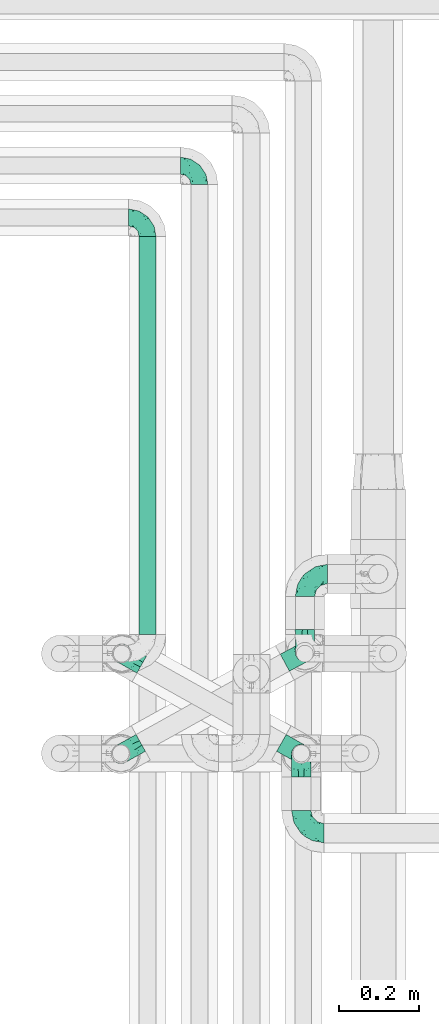
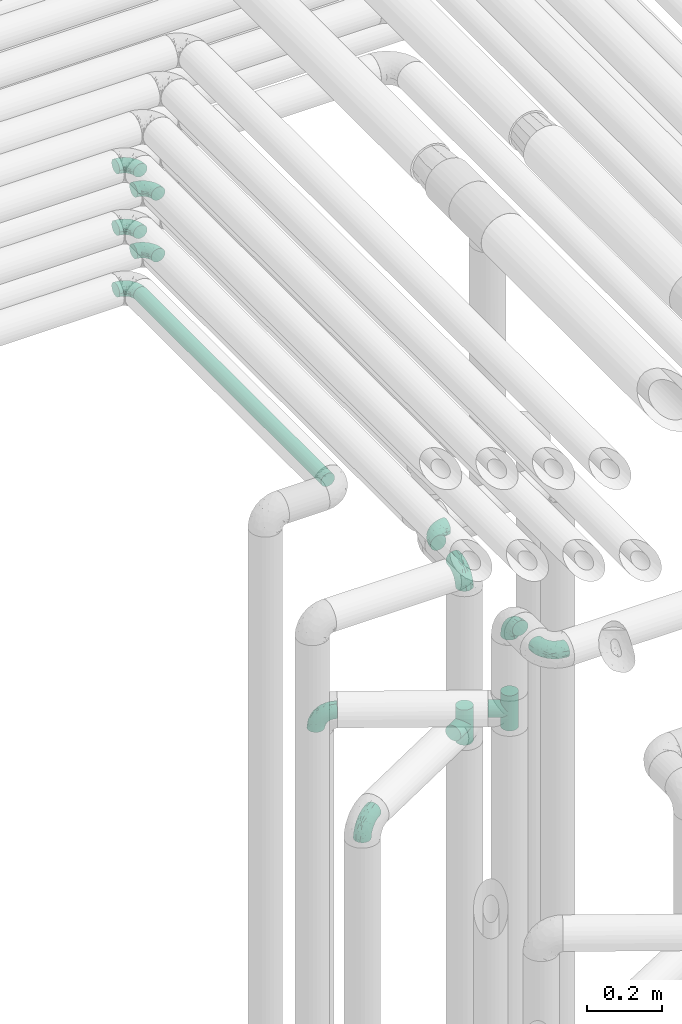
# One storey, part 601 of 824: 13 flow fittings, 1 flow segment.
"""IFC2X3 building model written with IfcOpenShell, lengths in millimetres."""

from ifc_helpers import new_model, entity, si_unit, converted_unit, derived_unit, direction, frame, origin, origin_2d_with_axis, place, context, subcontext, project, spatial, circle, extrude, faceted_brep, source, transform, mapped, material, type_object, type_shapes, element, save


model = new_model("IFC2X3")

# Units and contexts
model_context = context("Model", 3, precision=0.01, world=origin(), true_north=direction((6.12303176911189e-17, 1.0)))
body_context = subcontext(model_context, "Body", "Model", "MODEL_VIEW")
ifc_project = project(units=[si_unit("LENGTHUNIT", "METRE", prefix="MILLI"), si_unit("AREAUNIT", "SQUARE_METRE"), si_unit("VOLUMEUNIT", "CUBIC_METRE"), converted_unit("PLANEANGLEUNIT", "DEGREE", entity("IfcRatioMeasure", 0.0174532925199433), si_unit("PLANEANGLEUNIT", "RADIAN"), dimensions=[0, 0, 0, 0, 0, 0, 0]), si_unit("MASSUNIT", "GRAM", prefix="KILO"), derived_unit("MASSDENSITYUNIT", [(si_unit("MASSUNIT", "GRAM", prefix="KILO"), 1), (si_unit("LENGTHUNIT", "METRE"), -3)]), derived_unit("MOMENTOFINERTIAUNIT", [(si_unit("LENGTHUNIT", "METRE"), 4)]), si_unit("TIMEUNIT", "SECOND"), si_unit("FREQUENCYUNIT", "HERTZ"), si_unit("THERMODYNAMICTEMPERATUREUNIT", "DEGREE_CELSIUS"), derived_unit("THERMALTRANSMITTANCEUNIT", [(si_unit("MASSUNIT", "GRAM", prefix="KILO"), 1), (si_unit("THERMODYNAMICTEMPERATUREUNIT", "KELVIN"), -1), (si_unit("TIMEUNIT", "SECOND"), -3)]), derived_unit("VOLUMETRICFLOWRATEUNIT", [(si_unit("LENGTHUNIT", "METRE"), 3), (si_unit("TIMEUNIT", "SECOND"), -1)]), derived_unit("MASSFLOWRATEUNIT", [(si_unit("MASSUNIT", "GRAM", prefix="KILO"), 1), (si_unit("TIMEUNIT", "SECOND"), -1)]), derived_unit("ROTATIONALFREQUENCYUNIT", [(si_unit("TIMEUNIT", "SECOND"), -1)]), si_unit("ELECTRICCURRENTUNIT", "AMPERE"), si_unit("ELECTRICVOLTAGEUNIT", "VOLT"), si_unit("POWERUNIT", "WATT"), si_unit("FORCEUNIT", "NEWTON", prefix="KILO"), si_unit("ILLUMINANCEUNIT", "LUX"), si_unit("LUMINOUSFLUXUNIT", "LUMEN"), si_unit("LUMINOUSINTENSITYUNIT", "CANDELA"), derived_unit("USERDEFINED", [(si_unit("MASSUNIT", "GRAM", prefix="KILO"), -1), (si_unit("LENGTHUNIT", "METRE"), -2), (si_unit("TIMEUNIT", "SECOND"), 3), (si_unit("LUMINOUSFLUXUNIT", "LUMEN"), 1)]), derived_unit("LINEARVELOCITYUNIT", [(si_unit("LENGTHUNIT", "METRE"), 1), (si_unit("TIMEUNIT", "SECOND"), -1)]), si_unit("PRESSUREUNIT", "PASCAL"), derived_unit("USERDEFINED", [(si_unit("LENGTHUNIT", "METRE"), -2), (si_unit("MASSUNIT", "GRAM", prefix="KILO"), 1), (si_unit("TIMEUNIT", "SECOND"), -2)]), derived_unit("LINEARFORCEUNIT", [(si_unit("MASSUNIT", "GRAM", prefix="KILO"), 1), (si_unit("LENGTHUNIT", "METRE"), 1), (si_unit("TIMEUNIT", "SECOND"), -2), (si_unit("LENGTHUNIT", "METRE"), -1)]), derived_unit("PLANARFORCEUNIT", [(si_unit("MASSUNIT", "GRAM", prefix="KILO"), 1), (si_unit("LENGTHUNIT", "METRE"), 1), (si_unit("TIMEUNIT", "SECOND"), -2), (si_unit("LENGTHUNIT", "METRE"), -2)])], contexts=[model_context])

# Site, building, storey
site_placement = place(None, origin())
site = spatial("IfcSite", under=ifc_project, at=site_placement, CompositionType="ELEMENT")
building_placement = place(site_placement, origin())
building = spatial("IfcBuilding", under=site, at=building_placement, CompositionType="ELEMENT")
storey_placement = place(building_placement, frame((0.0, 0.0, 28200.0)))
storey = spatial("IfcBuildingStorey", under=building, at=storey_placement, CompositionType="ELEMENT", Elevation=28200.0)

# Flow segment
pipe_segment_type = type_object("IfcPipeSegmentType", PredefinedType="NOTDEFINED")
flow_segment_placement = place(storey_placement, frame((35317.29, 13054.2, 2977.25)))
element("IfcFlowSegment", 1, at=flow_segment_placement, inside=storey, type_object=pipe_segment_type, context=body_context, shape_type="SweptSolid", body=[
    extrude(circle(Radius=21.15, at=origin_2d_with_axis()), frame((22.75, 0.0, 22.75), z_axis=(0.0, 1.0, 0.0), x_axis=(-1.0, 0.0, 0.0)), (0.0, 0.0, 1.0), 997.797074054168),
])

# Flow fittings
ifc_material = material()
pipe_fitting_type_1 = type_object("IfcPipeFittingType", PredefinedType="NOTDEFINED", material=ifc_material)
shared_shape_1 = source(origin(), body_context, "Body", "Brep", [
    faceted_brep([(-57.0, 12.07, -20.91), (-57.0, 6.25, -23.33), (-57.0, 0.0, -24.15), (-57.0, -6.25, -23.33), (-57.0, -12.08, -20.91), (-57.0, -17.08, -17.08), (-57.0, -20.91, -12.08), (-57.0, -23.33, -6.25), (-57.0, -24.15, 0.0), (-57.0, -23.33, 6.25), (-57.0, -20.91, 12.07), (-57.0, -17.08, 17.08), (-57.0, -12.08, 20.91), (-57.0, -6.25, 23.33), (-57.0, 0.0, 24.15), (-57.0, 6.25, 23.33), (-57.0, 12.07, 20.91), (-57.0, 17.08, 17.08), (-57.0, 20.91, 12.07), (-57.0, 23.33, 6.25), (-57.0, 24.15, 0.0), (-57.0, 23.33, -6.25), (-57.0, 20.91, -12.08), (-57.0, 17.08, -17.08), (0.0, 57.0, -24.15), (-6.25, 57.0, -23.33), (-12.07, 57.0, -20.91), (-17.08, 57.0, -17.08), (-20.91, 57.0, -12.08), (-23.33, 57.0, -6.25), (-24.15, 57.0, 0.0), (-23.33, 57.0, 6.25), (-20.91, 57.0, 12.07), (-17.08, 57.0, 17.08), (-12.07, 57.0, 20.91), (-6.25, 57.0, 23.33), (0.0, 57.0, 24.15), (6.25, 57.0, 23.33), (12.08, 57.0, 20.91), (17.08, 57.0, 17.08), (20.91, 57.0, 12.07), (23.33, 57.0, 6.25), (24.15, 57.0, 0.0), (23.33, 57.0, -6.25), (20.91, 57.0, -12.08), (17.08, 57.0, -17.08), (12.08, 57.0, -20.91), (6.25, 57.0, -23.33), (14.9, 21.14, 6.17), (13.61, 24.64, 12.48), (6.23, 8.95, 8.98), (-41.47, -21.06, 0.0), (-41.92, -18.38, 13.72), (-24.64, -13.61, 12.48), (-37.37, -13.24, 18.15), (-6.8, -4.93, 8.18), (-21.76, -15.19, 6.22), (-12.78, -9.18, 0.0), (-37.73, -20.51, 7.75), (-7.38, 7.38, 20.24), (-23.37, -4.26, 20.42), (-11.9, -3.19, 15.86), (-42.14, -8.7, 21.82), (13.24, 37.37, 18.15), (9.33, 23.53, 16.85), (4.26, 23.37, 20.42), (2.77, 10.92, 15.55), (-29.46, 0.91, 23.52), (-44.13, 20.56, 15.69), (-39.25, 26.33, 10.88), (-49.02, 22.92, 9.96), (-34.58, 23.87, 17.15), (-15.8, 6.8, 22.81), (-8.67, 20.47, 23.88), (-18.12, 12.9, 24.08), (-48.29, 14.92, 19.65), (-44.06, -2.85, 23.78), (-9.23, 48.95, 22.58), (-3.78, 42.74, 24.07), (-40.34, 4.26, 24.09), (-44.02, 26.14, 5.46), (-44.04, 9.88, 22.74), (-4.95, 16.87, 22.52), (-2.75, 1.43, 12.5), (-25.48, 40.98, 10.71), (20.51, 37.73, 7.75), (18.38, 41.92, 13.72), (8.7, 42.14, 21.82), (-25.95, -17.97, 0.0), (2.85, 44.06, 23.78), (21.06, 41.47, 0.0), (17.97, 25.95, 0.0), (-24.04, -9.27, 17.13), (-33.26, 33.26, 5.86), (-28.55, 40.57, 0.0), (-40.57, 28.55, 0.0), (-25.29, 47.19, 4.06), (-27.01, 31.1, 16.77), (-15.7, 43.95, 19.9), (-20.27, 45.22, 15.61), (-30.53, 31.98, 12.64), (-11.28, 38.33, 22.92), (-9.97, 27.88, 24.09), (-20.15, 30.26, 21.25), (-31.25, 11.75, 23.64), (-28.75, 7.23, 24.15), (-29.53, 18.06, 22.27), (-28.44, 24.21, 20.02), (-37.55, 17.7, 20.26), (-15.88, 29.25, 22.99), (-20.82, 20.82, 23.44), (-0.91, 29.46, 23.52), (-13.5, -7.67, 12.04), (1.49, 1.56, 5.16), (8.86, 10.35, 4.59), (0.38, -0.38, 0.0), (9.18, 12.78, 0.0), (-37.37, -13.24, -18.15), (8.86, 10.35, -4.59), (-45.22, 20.27, -15.61), (-43.95, 15.7, -19.9), (-38.33, 11.28, -22.92), (-48.95, 9.23, -22.58), (-47.19, 25.29, -4.06), (-33.26, 33.26, -5.86), (18.38, 41.92, -13.72), (-30.26, 20.15, -21.25), (2.85, 44.06, -23.78), (-4.26, 40.34, -24.09), (-40.98, 25.48, -10.71), (-41.92, -18.38, -13.72), (9.25, 23.5, -16.92), (4.26, 23.37, -20.42), (13.24, 37.37, -18.15), (-37.73, -20.51, -7.75), (-11.75, 31.25, -23.64), (-7.23, 28.75, -24.15), (-12.9, 18.12, -24.08), (8.7, 42.14, -21.82), (-44.06, -2.85, -23.78), (-6.8, 15.8, -22.81), (-20.47, 8.67, -23.88), (-24.64, -13.61, -12.48), (-42.74, 3.78, -24.07), (-18.06, 29.53, -22.27), (-24.21, 28.44, -20.02), (-27.88, 9.97, -24.09), (-31.1, 27.01, -16.77), (-26.14, 44.02, -5.46), (14.9, 21.14, -6.17), (20.51, 37.73, -7.75), (-9.88, 44.04, -22.74), (-20.56, 44.13, -15.69), (-21.76, -15.19, -6.22), (-13.5, -7.67, -12.04), (-24.14, -9.76, -16.74), (-11.9, -3.19, -15.86), (-14.92, 48.29, -19.65), (-23.37, -4.26, -20.42), (-0.91, 29.46, -23.52), (-26.33, 39.25, -10.88), (-23.87, 34.58, -17.15), (-42.14, -8.7, -21.82), (-22.92, 49.02, -9.96), (13.61, 24.64, -12.48), (-31.98, 30.53, -12.64), (-16.87, 4.95, -22.52), (-17.7, 37.55, -20.26), (-29.25, 15.88, -22.99), (-20.82, 20.82, -23.44), (-29.46, 0.91, -23.52), (-7.38, 7.38, -20.24), (2.77, 10.92, -15.55), (6.23, 8.95, -8.98), (-6.8, -4.93, -8.18), (-2.81, 1.41, -12.54), (1.49, 1.56, -5.16)], [[[0, 1, 2, 3, 4, 5, 6, 7, 8, 9, 10, 11, 12, 13, 14, 15, 16, 17, 18, 19, 20, 21, 22, 23]], [[24, 25, 26, 27, 28, 29, 30, 31, 32, 33, 34, 35, 36, 37, 38, 39, 40, 41, 42, 43, 44, 45, 46, 47]], [[48, 49, 50]], [[9, 8, 51]], [[52, 53, 54]], [[55, 56, 57]], [[10, 58, 52]], [[9, 58, 10]], [[59, 60, 61]], [[54, 12, 11]], [[54, 62, 12]], [[63, 39, 38]], [[64, 65, 66]], [[62, 60, 67]], [[68, 69, 70]], [[71, 69, 68]], [[72, 73, 74]], [[16, 75, 17]], [[13, 76, 14]], [[35, 77, 78]], [[14, 79, 15]], [[17, 68, 18]], [[14, 76, 79]], [[20, 19, 80]], [[70, 19, 18]], [[81, 15, 79]], [[15, 81, 16]], [[73, 72, 82]], [[66, 83, 50]], [[32, 31, 84]], [[85, 86, 49]], [[63, 87, 65]], [[56, 58, 88]], [[36, 89, 37]], [[85, 41, 40]], [[36, 35, 78]], [[90, 41, 85]], [[40, 39, 86]], [[12, 62, 13]], [[86, 85, 40]], [[48, 85, 49]], [[85, 91, 90]], [[87, 38, 37]], [[92, 60, 54]], [[80, 69, 93]], [[93, 94, 95]], [[10, 52, 11]], [[94, 96, 30]], [[97, 98, 99]], [[80, 93, 95]], [[100, 97, 84]], [[99, 98, 33]], [[101, 102, 78]], [[103, 101, 98]], [[96, 31, 30]], [[77, 98, 101]], [[77, 35, 34]], [[34, 33, 98]], [[9, 51, 58]], [[87, 63, 38]], [[104, 105, 74]], [[106, 103, 107]], [[106, 81, 104]], [[75, 68, 17]], [[108, 107, 71]], [[33, 32, 99]], [[109, 103, 110]], [[101, 109, 102]], [[89, 78, 111]], [[53, 52, 58]], [[54, 11, 52]], [[60, 62, 54]], [[88, 58, 51]], [[76, 62, 67]], [[53, 112, 92]], [[60, 59, 72]], [[39, 63, 86]], [[49, 86, 63]], [[89, 87, 37]], [[42, 41, 90]], [[111, 82, 65]], [[111, 65, 87]], [[65, 59, 66]], [[104, 81, 79]], [[75, 81, 108]], [[32, 84, 99]], [[97, 99, 84]], [[98, 97, 103]], [[106, 107, 108]], [[74, 102, 110]], [[111, 78, 102]], [[74, 110, 104]], [[74, 67, 72]], [[61, 92, 112]], [[66, 59, 61]], [[56, 53, 58]], [[66, 50, 49]], [[61, 112, 83]], [[66, 49, 64]], [[78, 89, 36]], [[87, 89, 111]], [[62, 76, 13]], [[79, 76, 67]], [[100, 93, 69]], [[96, 93, 84]], [[55, 113, 50]], [[113, 114, 50]], [[104, 79, 105]], [[106, 104, 110]], [[20, 80, 95]], [[85, 48, 91]], [[115, 114, 113]], [[116, 91, 48]], [[70, 80, 19]], [[93, 96, 94]], [[84, 31, 96]], [[103, 106, 110]], [[81, 106, 108]], [[103, 97, 107]], [[71, 107, 97]], [[71, 97, 100]], [[108, 71, 68]], [[79, 67, 105]], [[67, 74, 105]], [[115, 113, 57]], [[112, 56, 55]], [[56, 88, 57]], [[60, 72, 67]], [[82, 72, 59]], [[65, 82, 59]], [[82, 111, 73]], [[111, 102, 73]], [[102, 74, 73]], [[81, 75, 16]], [[68, 75, 108]], [[68, 70, 18]], [[80, 70, 69]], [[98, 77, 34]], [[78, 77, 101]], [[93, 100, 84]], [[71, 100, 69]], [[102, 109, 110]], [[101, 103, 109]], [[53, 92, 54]], [[61, 60, 92]], [[56, 112, 53]], [[83, 112, 55]], [[50, 83, 55]], [[61, 83, 66]], [[49, 63, 64]], [[65, 64, 63]], [[57, 113, 55]], [[114, 115, 116]], [[116, 48, 114]], [[48, 50, 114]], [[117, 5, 4]], [[116, 115, 118]], [[119, 120, 23]], [[121, 122, 120]], [[95, 123, 20]], [[0, 23, 120]], [[124, 95, 94]], [[125, 45, 44]], [[121, 120, 126]], [[24, 127, 128]], [[22, 21, 129]], [[0, 122, 1]], [[5, 117, 130]], [[131, 132, 133]], [[134, 88, 51]], [[135, 136, 137]], [[6, 5, 130]], [[46, 138, 47]], [[139, 3, 2]], [[140, 141, 137]], [[6, 134, 7]], [[134, 130, 142]], [[143, 2, 1]], [[144, 126, 145]], [[121, 146, 143]], [[147, 120, 119]], [[94, 148, 124]], [[149, 150, 91]], [[30, 29, 148]], [[151, 25, 128]], [[27, 152, 28]], [[134, 153, 88]], [[154, 155, 156]], [[27, 26, 157]], [[151, 26, 25]], [[155, 158, 156]], [[24, 47, 127]], [[1, 122, 143]], [[138, 132, 159]], [[160, 152, 161]], [[24, 128, 25]], [[46, 133, 138]], [[162, 117, 4]], [[148, 160, 124]], [[152, 160, 163]], [[154, 142, 155]], [[45, 125, 133]], [[133, 46, 45]], [[125, 164, 133]], [[51, 7, 134]], [[42, 90, 43]], [[165, 147, 129]], [[153, 134, 142]], [[43, 150, 44]], [[162, 4, 3]], [[141, 140, 166]], [[117, 162, 158]], [[163, 29, 28]], [[43, 90, 150]], [[123, 21, 20]], [[144, 151, 135]], [[157, 152, 27]], [[167, 145, 161]], [[23, 22, 119]], [[168, 126, 169]], [[121, 168, 146]], [[139, 143, 170]], [[142, 130, 117]], [[8, 7, 51]], [[134, 6, 130]], [[139, 162, 3]], [[170, 166, 158]], [[170, 158, 162]], [[158, 171, 156]], [[44, 150, 125]], [[91, 150, 90]], [[164, 125, 150]], [[132, 138, 133]], [[127, 138, 159]], [[131, 164, 172]], [[132, 171, 140]], [[135, 151, 128]], [[157, 151, 167]], [[22, 129, 119]], [[147, 119, 129]], [[120, 147, 126]], [[144, 145, 167]], [[137, 146, 169]], [[170, 143, 146]], [[137, 169, 135]], [[137, 159, 140]], [[171, 172, 156]], [[173, 174, 175]], [[156, 175, 154]], [[174, 57, 153]], [[132, 172, 171]], [[172, 164, 173]], [[143, 139, 2]], [[162, 139, 170]], [[138, 127, 47]], [[128, 127, 159]], [[165, 124, 160]], [[123, 124, 129]], [[149, 173, 164]], [[176, 174, 173]], [[135, 128, 136]], [[144, 135, 169]], [[150, 149, 164]], [[176, 118, 115]], [[149, 91, 116]], [[30, 148, 94]], [[163, 148, 29]], [[124, 123, 95]], [[129, 21, 123]], [[126, 144, 169]], [[151, 144, 167]], [[126, 147, 145]], [[161, 145, 147]], [[161, 147, 165]], [[167, 161, 152]], [[128, 159, 136]], [[159, 137, 136]], [[154, 153, 142]], [[132, 140, 159]], [[174, 176, 57]], [[57, 88, 153]], [[166, 140, 171]], [[158, 166, 171]], [[166, 170, 141]], [[170, 146, 141]], [[146, 137, 141]], [[151, 157, 26]], [[152, 157, 167]], [[152, 163, 28]], [[148, 163, 160]], [[120, 122, 0]], [[143, 122, 121]], [[124, 165, 129]], [[161, 165, 160]], [[146, 168, 169]], [[121, 126, 168]], [[142, 117, 155]], [[158, 155, 117]], [[175, 156, 172]], [[153, 154, 174]], [[173, 175, 172]], [[174, 154, 175]], [[164, 131, 133]], [[172, 132, 131]], [[176, 173, 118]], [[57, 176, 115]], [[173, 149, 118]], [[149, 116, 118]]]),
])
type_shapes(pipe_fitting_type_1, [shared_shape_1])
for number, where, z_axis, x_axis in (
    (2, (35734.24, 13010.49, 2600.0), (-1.0, 0.0, 0.0), (0.0, 0.0, 1.0)),
    (3, (35734.24, 13206.08, 2600.0), (0.0, 0.0, 1.0), (-1.0, 0.0, 0.0)),
    (4, (35725.03, 12754.46, 2600.0), (1.0, 0.0, 0.0), (0.0, 0.0, 1.0)),
    (5, (35725.03, 12556.08, 2600.0), (0.0, 0.0, 1.0), (0.0, -1.0, 0.0)),
    (6, (35275.34, 13006.53, 2305.0), (-0.488239231862421, -0.872709832917215, 0.0), (-0.872709832917215, 0.488239231862421, 0.0)),
    (7, (35272.9, 12754.86, 2100.0), (0.486104408033654, -0.873900740639491, 0.0), (-0.873900740639491, -0.486104408033654, 0.0)),
):
    element("IfcFlowFitting", number, at=place(storey_placement, frame(where, z_axis=z_axis, x_axis=x_axis)), inside=storey, type_object=pipe_fitting_type_1, material=ifc_material, context=body_context, shape_type="MappedRepresentation", body=[
        mapped(shared_shape_1, transform((0.0, 0.0, 0.0), scale=1.0)),
    ])
pipe_fitting_type_2 = type_object("IfcPipeFittingType", PredefinedType="NOTDEFINED", material=ifc_material)
shared_shape_2 = source(origin(), body_context, "Body", "Brep", [
    faceted_brep([(-48.0, 10.6, -18.36), (-48.0, 5.49, -20.48), (-48.0, 0.0, -21.2), (-48.0, -5.49, -20.48), (-48.0, -10.6, -18.36), (-48.0, -14.99, -14.99), (-48.0, -18.36, -10.6), (-48.0, -20.48, -5.49), (-48.0, -21.2, 0.0), (-48.0, -20.48, 5.49), (-48.0, -18.36, 10.6), (-48.0, -14.99, 14.99), (-48.0, -10.6, 18.36), (-48.0, -5.49, 20.48), (-48.0, 0.0, 21.2), (-48.0, 5.49, 20.48), (-48.0, 10.6, 18.36), (-48.0, 14.99, 14.99), (-48.0, 18.36, 10.6), (-48.0, 20.48, 5.49), (-48.0, 21.2, 0.0), (-48.0, 20.48, -5.49), (-48.0, 18.36, -10.6), (-48.0, 14.99, -14.99), (0.0, 48.0, -21.2), (-5.49, 48.0, -20.48), (-10.6, 48.0, -18.36), (-14.99, 48.0, -14.99), (-18.36, 48.0, -10.6), (-20.48, 48.0, -5.49), (-21.2, 48.0, 0.0), (-20.48, 48.0, 5.49), (-18.36, 48.0, 10.6), (-14.99, 48.0, 14.99), (-10.6, 48.0, 18.36), (-5.49, 48.0, 20.48), (0.0, 48.0, 21.2), (5.49, 48.0, 20.48), (10.6, 48.0, 18.36), (14.99, 48.0, 14.99), (18.36, 48.0, 10.6), (20.48, 48.0, 5.49), (21.2, 48.0, 0.0), (20.48, 48.0, -5.49), (18.36, 48.0, -10.6), (14.99, 48.0, -14.99), (10.6, 48.0, -18.36), (5.49, 48.0, -20.48), (-35.25, -16.22, 12.01), (-34.76, -18.57, 0.0), (-20.87, -12.37, 10.9), (-31.49, -11.78, 15.9), (-37.0, -2.58, 20.86), (-33.89, 3.62, 21.15), (-31.81, -18.14, 6.76), (-5.78, 5.78, 17.67), (-19.42, -4.1, 17.86), (-9.6, -3.39, 13.73), (-35.44, -7.73, 19.13), (11.78, 31.49, 15.9), (-5.93, -5.46, 6.95), (-18.45, -13.78, 5.46), (-10.29, -8.43, 0.0), (-24.6, 0.55, 20.62), (-37.28, 17.94, 13.81), (-33.38, 22.85, 9.59), (-41.46, 20.06, 8.75), (-29.51, 20.45, 15.16), (-15.04, 10.79, 21.13), (-7.08, 16.98, 20.93), (-8.39, 23.51, 21.15), (-40.86, 13.03, 17.26), (-8.05, 41.26, 19.83), (-3.21, 35.97, 21.14), (8.53, 19.66, 14.74), (4.1, 19.42, 17.86), (-37.72, 22.66, 4.78), (-37.07, 8.58, 19.98), (-13.0, 5.43, 19.97), (-3.78, 13.93, 19.7), (3.02, 8.69, 13.43), (-2.27, -0.05, 10.65), (6.22, 6.99, 7.09), (-22.25, 34.6, 9.45), (18.14, 31.81, 6.76), (16.22, 35.25, 12.01), (12.37, 20.87, 10.9), (7.73, 35.44, 19.13), (-21.52, -15.93, 0.0), (2.58, 37.0, 20.86), (18.57, 34.76, 0.0), (13.78, 18.45, 5.46), (15.93, 21.52, 0.0), (-20.03, -8.54, 14.9), (-28.6, 28.6, 5.16), (-24.79, 34.6, 0.0), (-34.6, 24.79, 0.0), (-22.81, 37.41, 4.68), (-23.36, 26.33, 14.79), (-13.68, 37.05, 17.49), (-17.72, 38.12, 13.73), (-26.25, 27.3, 11.24), (-9.71, 32.34, 20.14), (-17.26, 25.6, 18.71), (-26.33, 9.99, 20.77), (-24.06, 6.05, 21.2), (-25.02, 15.46, 19.56), (-24.3, 20.72, 17.57), (-31.95, 15.23, 17.8), (-13.53, 24.7, 20.21), (-17.6, 17.6, 20.6), (-0.55, 24.6, 20.62), (-11.41, -7.48, 10.43), (0.93, -0.93, 0.0), (8.43, 10.29, 0.0), (-11.41, -7.48, -10.43), (-20.1, -8.84, -14.66), (-9.6, -3.39, -13.73), (7.73, 35.44, -19.13), (4.1, 19.42, -17.86), (-0.55, 24.6, -20.62), (-38.12, 17.72, -13.73), (-37.05, 13.68, -17.49), (-32.34, 9.71, -20.14), (-41.26, 8.05, -19.83), (-37.41, 22.81, -4.68), (-23.51, 8.39, -21.15), (-35.97, 3.21, -21.14), (-28.6, 28.6, -5.16), (-31.81, -18.14, -6.76), (-18.45, -13.78, -5.46), (-25.6, 17.26, -18.71), (-19.42, -4.1, -17.86), (-17.94, 37.28, -13.81), (-22.85, 33.38, -9.59), (-20.06, 41.46, -8.75), (-31.49, -11.78, -15.9), (-35.25, -16.22, -12.01), (8.53, 19.66, -14.74), (11.78, 31.49, -15.9), (-9.99, 26.33, -20.77), (-6.05, 24.06, -21.2), (-10.79, 15.04, -21.13), (-37.0, -2.58, -20.86), (-16.98, 7.08, -20.93), (-5.43, 13.0, -19.97), (-13.93, 3.78, -19.7), (-20.87, -12.37, -10.9), (-26.33, 23.36, -14.79), (-22.66, 37.72, -4.78), (13.78, 18.45, -5.46), (18.14, 31.81, -6.76), (-15.46, 25.02, -19.56), (-20.72, 24.3, -17.57), (16.22, 35.25, -12.01), (-13.03, 40.86, -17.26), (-8.58, 37.07, -19.98), (2.58, 37.0, -20.86), (-3.62, 33.89, -21.15), (-34.6, 22.25, -9.45), (6.22, 6.99, -7.09), (-20.45, 29.51, -15.16), (-35.44, -7.73, -19.13), (12.37, 20.87, -10.9), (-27.3, 26.25, -11.24), (-15.23, 31.95, -17.8), (-24.7, 13.53, -20.21), (-24.6, 0.55, -20.62), (-5.78, 5.78, -17.67), (-17.6, 17.6, -20.6), (3.02, 8.69, -13.43), (-5.93, -5.46, -6.95), (-2.27, -0.05, -10.65)], [[[0, 1, 2, 3, 4, 5, 6, 7, 8, 9, 10, 11, 12, 13, 14, 15, 16, 17, 18, 19, 20, 21, 22, 23]], [[24, 25, 26, 27, 28, 29, 30, 31, 32, 33, 34, 35, 36, 37, 38, 39, 40, 41, 42, 43, 44, 45, 46, 47]], [[10, 48, 11]], [[9, 8, 49]], [[48, 50, 51]], [[14, 52, 53]], [[10, 54, 48]], [[9, 54, 10]], [[55, 56, 57]], [[51, 12, 11]], [[51, 58, 12]], [[59, 39, 38]], [[60, 61, 62]], [[58, 56, 63]], [[64, 65, 66]], [[67, 65, 64]], [[68, 69, 70]], [[16, 71, 17]], [[13, 52, 14]], [[35, 72, 73]], [[14, 53, 15]], [[17, 64, 18]], [[74, 59, 75]], [[20, 19, 76]], [[66, 19, 18]], [[77, 15, 53]], [[15, 77, 16]], [[69, 78, 79]], [[80, 81, 82]], [[32, 31, 83]], [[84, 85, 86]], [[59, 87, 75]], [[61, 54, 88]], [[36, 89, 37]], [[84, 41, 40]], [[36, 35, 73]], [[90, 41, 84]], [[40, 39, 85]], [[12, 58, 13]], [[85, 84, 40]], [[91, 84, 86]], [[84, 92, 90]], [[87, 38, 37]], [[93, 56, 51]], [[65, 94, 76]], [[94, 95, 96]], [[84, 91, 92]], [[95, 97, 30]], [[98, 99, 100]], [[76, 94, 96]], [[101, 98, 83]], [[100, 99, 33]], [[102, 70, 73]], [[103, 102, 99]], [[94, 97, 95]], [[72, 99, 102]], [[72, 35, 34]], [[34, 33, 99]], [[9, 49, 54]], [[87, 59, 38]], [[104, 105, 68]], [[106, 103, 107]], [[106, 77, 104]], [[71, 64, 17]], [[108, 107, 67]], [[33, 32, 100]], [[109, 103, 110]], [[102, 109, 70]], [[89, 73, 111]], [[50, 48, 54]], [[51, 11, 48]], [[56, 58, 51]], [[88, 54, 49]], [[52, 58, 63]], [[50, 112, 93]], [[56, 55, 78]], [[39, 59, 85]], [[86, 85, 59]], [[89, 87, 37]], [[42, 41, 90]], [[111, 79, 75]], [[111, 75, 87]], [[75, 55, 80]], [[104, 77, 53]], [[71, 77, 108]], [[32, 83, 100]], [[98, 100, 83]], [[99, 98, 103]], [[106, 107, 108]], [[68, 70, 110]], [[111, 73, 70]], [[68, 110, 104]], [[68, 63, 78]], [[57, 93, 112]], [[80, 55, 57]], [[61, 50, 54]], [[80, 82, 86]], [[81, 57, 112]], [[74, 86, 59]], [[60, 113, 82]], [[82, 114, 91]], [[101, 94, 65]], [[97, 94, 83]], [[73, 89, 36]], [[87, 89, 111]], [[58, 52, 13]], [[53, 52, 63]], [[104, 53, 105]], [[106, 104, 110]], [[20, 76, 96]], [[76, 19, 66]], [[103, 106, 110]], [[77, 106, 108]], [[103, 98, 107]], [[67, 107, 98]], [[67, 98, 101]], [[108, 67, 64]], [[53, 63, 105]], [[63, 68, 105]], [[83, 31, 97]], [[30, 97, 31]], [[62, 113, 60]], [[112, 61, 60]], [[61, 88, 62]], [[86, 82, 91]], [[56, 78, 63]], [[114, 82, 113]], [[114, 92, 91]], [[79, 78, 55]], [[75, 79, 55]], [[69, 79, 111]], [[70, 69, 111]], [[78, 69, 68]], [[77, 71, 16]], [[64, 71, 108]], [[64, 66, 18]], [[76, 66, 65]], [[99, 72, 34]], [[73, 72, 102]], [[94, 101, 83]], [[67, 101, 65]], [[75, 80, 74]], [[80, 86, 74]], [[70, 109, 110]], [[102, 103, 109]], [[50, 93, 51]], [[57, 56, 93]], [[61, 112, 50]], [[81, 112, 60]], [[82, 81, 60]], [[80, 57, 81]], [[115, 116, 117]], [[118, 119, 120]], [[121, 122, 23]], [[123, 124, 122]], [[96, 125, 20]], [[123, 126, 127]], [[128, 96, 95]], [[129, 130, 88]], [[123, 122, 131]], [[116, 132, 117]], [[133, 134, 135]], [[0, 124, 1]], [[5, 136, 137]], [[138, 119, 139]], [[129, 88, 49]], [[140, 141, 142]], [[6, 5, 137]], [[46, 118, 47]], [[143, 3, 2]], [[144, 145, 146]], [[6, 129, 7]], [[129, 137, 147]], [[127, 2, 1]], [[148, 122, 121]], [[128, 125, 96]], [[134, 128, 149]], [[95, 149, 128]], [[150, 151, 92]], [[30, 29, 149]], [[152, 131, 153]], [[27, 133, 28]], [[154, 45, 44]], [[136, 5, 4]], [[27, 26, 155]], [[156, 26, 25]], [[24, 157, 158]], [[24, 47, 157]], [[22, 21, 159]], [[160, 150, 114]], [[134, 133, 161]], [[142, 144, 126]], [[46, 139, 118]], [[162, 136, 4]], [[156, 25, 158]], [[1, 124, 127]], [[115, 147, 116]], [[45, 154, 139]], [[139, 46, 45]], [[154, 163, 139]], [[162, 4, 3]], [[42, 90, 43]], [[130, 129, 147]], [[49, 7, 129]], [[43, 151, 44]], [[0, 23, 122]], [[24, 158, 25]], [[136, 162, 132]], [[135, 29, 28]], [[43, 90, 151]], [[164, 148, 159]], [[152, 156, 140]], [[155, 133, 27]], [[165, 153, 161]], [[23, 22, 121]], [[123, 131, 166]], [[123, 166, 126]], [[143, 127, 167]], [[147, 137, 136]], [[8, 7, 49]], [[129, 6, 137]], [[143, 162, 3]], [[167, 146, 132]], [[167, 132, 162]], [[132, 168, 117]], [[44, 151, 154]], [[92, 151, 90]], [[163, 154, 151]], [[119, 118, 139]], [[157, 118, 120]], [[138, 139, 163]], [[119, 168, 145]], [[140, 156, 158]], [[155, 156, 165]], [[22, 159, 121]], [[148, 121, 159]], [[122, 148, 131]], [[152, 153, 165]], [[142, 126, 169]], [[167, 127, 126]], [[142, 169, 140]], [[142, 120, 145]], [[168, 170, 117]], [[160, 171, 172]], [[115, 172, 171]], [[171, 62, 130]], [[119, 170, 168]], [[170, 163, 160]], [[150, 163, 151]], [[113, 171, 160]], [[164, 128, 134]], [[125, 128, 159]], [[127, 143, 2]], [[162, 143, 167]], [[118, 157, 47]], [[158, 157, 120]], [[140, 158, 141]], [[152, 140, 169]], [[30, 149, 95]], [[149, 29, 135]], [[131, 152, 169]], [[156, 152, 165]], [[131, 148, 153]], [[161, 153, 148]], [[161, 148, 164]], [[165, 161, 133]], [[158, 120, 141]], [[120, 142, 141]], [[159, 21, 125]], [[20, 125, 21]], [[115, 130, 147]], [[114, 113, 160]], [[62, 171, 113]], [[62, 88, 130]], [[160, 163, 150]], [[150, 92, 114]], [[119, 145, 120]], [[146, 145, 168]], [[132, 146, 168]], [[144, 146, 167]], [[126, 144, 167]], [[145, 144, 142]], [[156, 155, 26]], [[133, 155, 165]], [[133, 135, 28]], [[149, 135, 134]], [[122, 124, 0]], [[127, 124, 123]], [[128, 164, 159]], [[161, 164, 134]], [[163, 170, 138]], [[170, 119, 138]], [[131, 169, 166]], [[126, 166, 169]], [[147, 136, 116]], [[132, 116, 136]], [[172, 115, 117]], [[130, 115, 171]], [[117, 170, 172]], [[160, 172, 170]]]),
])
type_shapes(pipe_fitting_type_2, [shared_shape_2])
for number, where, z_axis, x_axis in (
    (8, (35470.03, 14230.0, 3000.0), (0.0, 0.0, 1.0), (0.0, 1.0, 0.0)),
    (9, (35340.03, 14100.0, 3000.0), (0.0, 0.0, 1.0), (0.0, 1.0, 0.0)),
    (10, (35340.03, 14100.0, 3200.0), (0.0, 0.0, 1.0), (0.0, 1.0, 0.0)),
    (11, (35470.03, 14230.0, 3200.0), (0.0, 0.0, 1.0), (0.0, 1.0, 0.0)),
    (12, (35340.03, 14100.0, 3400.0), (0.0, 0.0, 1.0), (0.0, 1.0, 0.0)),
):
    element("IfcFlowFitting", number, at=place(storey_placement, frame(where, z_axis=z_axis, x_axis=x_axis)), inside=storey, type_object=pipe_fitting_type_2, material=ifc_material, context=body_context, shape_type="MappedRepresentation", body=[
        mapped(shared_shape_2, transform((0.0, 0.0, 0.0), scale=1.0)),
    ])
pipe_fitting_type_3 = type_object("IfcPipeFittingType", PredefinedType="NOTDEFINED", material=ifc_material)
shared_shape_3 = source(origin(), body_context, "Body", "Brep", [
    faceted_brep([(-57.0, 12.07, -20.91), (-57.0, 6.25, -23.33), (-57.0, 0.0, -24.15), (-57.0, -6.25, -23.33), (-57.0, -12.08, -20.91), (-57.0, -17.08, -17.08), (-57.0, -20.91, -12.08), (-57.0, -23.33, -6.25), (-57.0, -24.15, 0.0), (-57.0, -23.33, 6.25), (-57.0, -20.91, 12.07), (-57.0, -17.08, 17.08), (-57.0, -12.08, 20.91), (-57.0, -6.25, 23.33), (-57.0, 0.0, 24.15), (-57.0, 6.25, 23.33), (-57.0, 12.07, 20.91), (-57.0, 17.08, 17.08), (-57.0, 20.91, 12.07), (-57.0, 23.33, 6.25), (-57.0, 24.15, 0.0), (-57.0, 23.33, -6.25), (-57.0, 20.91, -12.08), (-57.0, 17.08, -17.08), (57.0, 0.0, -24.15), (57.0, 6.25, -23.33), (57.0, 12.07, -20.91), (57.0, 17.08, -17.08), (57.0, 20.91, -12.08), (57.0, 23.33, -6.25), (57.0, 24.15, 0.0), (57.0, 23.33, 6.25), (57.0, 20.91, 12.07), (57.0, 17.08, 17.08), (57.0, 12.07, 20.91), (57.0, 6.25, 23.33), (57.0, 0.0, 24.15), (57.0, -6.25, 23.33), (57.0, -12.08, 20.91), (57.0, -17.08, 17.08), (57.0, -20.91, 12.07), (57.0, -23.33, 6.25), (57.0, -24.15, 0.0), (57.0, -23.33, -6.25), (57.0, -20.91, -12.08), (57.0, -17.08, -17.08), (57.0, -12.08, -20.91), (57.0, -6.25, -23.33), (23.27, -23.27, 6.45), (24.15, -24.15, 0.0), (-24.15, -24.15, 0.0), (20.9, -20.9, 12.1), (13.54, -13.54, 20.0), (17.52, -17.52, 16.62), (-23.27, -23.27, 6.45), (-20.9, -20.9, 12.1), (-17.52, -17.52, 16.62), (-13.54, -13.54, 20.0), (-9.19, -9.19, 22.33), (9.19, -9.19, 22.33), (4.64, -4.64, 23.7), (0.0, 0.0, 24.15), (-4.64, -4.64, 23.7), (4.64, -4.64, -23.7), (0.0, 0.0, -24.15), (-4.64, -4.64, -23.7), (-9.19, -9.19, -22.33), (9.19, -9.19, -22.33), (13.54, -13.54, -20.0), (17.52, -17.52, -16.62), (20.9, -20.9, -12.1), (23.27, -23.27, -6.45), (-13.54, -13.54, -20.0), (-17.52, -17.52, -16.62), (-23.27, -23.27, -6.45), (-20.9, -20.9, -12.1), (0.0, -57.0, -24.15), (6.25, -57.0, -23.33), (12.08, -57.0, -20.91), (17.08, -57.0, -17.08), (20.91, -57.0, -12.08), (23.33, -57.0, -6.25), (24.15, -57.0, 0.0), (23.33, -57.0, 6.25), (20.91, -57.0, 12.07), (17.08, -57.0, 17.08), (12.08, -57.0, 20.91), (6.25, -57.0, 23.33), (0.0, -57.0, 24.15), (-6.25, -57.0, 23.33), (-12.07, -57.0, 20.91), (-17.08, -57.0, 17.08), (-20.91, -57.0, 12.07), (-23.33, -57.0, 6.25), (-24.15, -57.0, 0.0), (-23.33, -57.0, -6.25), (-20.91, -57.0, -12.08), (-17.08, -57.0, -17.08), (-12.07, -57.0, -20.91), (-6.25, -57.0, -23.33)], [[[0, 1, 2, 3, 4, 5, 6, 7, 8, 9, 10, 11, 12, 13, 14, 15, 16, 17, 18, 19, 20, 21, 22, 23]], [[24, 25, 26, 27, 28, 29, 30, 31, 32, 33, 34, 35, 36, 37, 38, 39, 40, 41, 42, 43, 44, 45, 46, 47]], [[41, 40, 48]], [[42, 41, 49]], [[50, 9, 8]], [[49, 41, 48]], [[40, 51, 48]], [[39, 38, 52]], [[51, 40, 53]], [[52, 53, 39]], [[53, 40, 39]], [[50, 54, 9]], [[9, 54, 10]], [[54, 55, 10]], [[56, 57, 11]], [[11, 10, 56]], [[11, 57, 12]], [[56, 10, 55]], [[12, 57, 58]], [[52, 38, 59]], [[60, 36, 61]], [[62, 61, 14]], [[59, 37, 60]], [[37, 59, 38]], [[60, 37, 36]], [[61, 36, 35, 15, 14]], [[32, 31, 19, 18]], [[17, 16, 34, 33]], [[18, 17, 33, 32]], [[35, 34, 16, 15]], [[20, 19, 31, 30]], [[62, 13, 58]], [[13, 62, 14]], [[58, 13, 12]], [[27, 23, 22, 28]], [[22, 21, 29, 28]], [[0, 23, 27, 26]], [[20, 30, 29, 21]], [[24, 47, 63]], [[24, 64, 2, 1, 25]], [[64, 24, 63]], [[2, 64, 65]], [[26, 25, 1, 0]], [[65, 66, 3]], [[2, 65, 3]], [[66, 4, 3]], [[63, 47, 67]], [[46, 45, 68]], [[69, 68, 45]], [[44, 70, 69]], [[69, 45, 44]], [[46, 68, 67]], [[43, 42, 49]], [[7, 50, 8]], [[43, 71, 44]], [[71, 43, 49]], [[44, 71, 70]], [[72, 4, 66]], [[72, 5, 4]], [[5, 72, 73]], [[5, 73, 6]], [[74, 50, 7]], [[75, 74, 6]], [[74, 7, 6]], [[75, 6, 73]], [[46, 67, 47]], [[76, 77, 78, 79, 80, 81, 82, 83, 84, 85, 86, 87, 88, 89, 90, 91, 92, 93, 94, 95, 96, 97, 98, 99]], [[50, 94, 93]], [[54, 50, 93]], [[91, 90, 57]], [[56, 92, 91]], [[54, 93, 92]], [[58, 90, 89]], [[55, 54, 92]], [[56, 55, 92]], [[58, 57, 90]], [[88, 61, 62]], [[58, 89, 62]], [[56, 91, 57]], [[62, 89, 88]], [[60, 88, 87]], [[86, 59, 87]], [[84, 83, 48]], [[53, 85, 84]], [[52, 86, 85]], [[49, 83, 82]], [[59, 60, 87]], [[52, 59, 86]], [[49, 48, 83]], [[51, 53, 84]], [[48, 51, 84]], [[52, 85, 53]], [[88, 60, 61]], [[82, 81, 49]], [[71, 49, 81]], [[69, 80, 79]], [[79, 78, 68]], [[71, 81, 80]], [[67, 78, 77]], [[70, 71, 80]], [[69, 70, 80]], [[67, 68, 78]], [[76, 64, 63]], [[67, 77, 63]], [[69, 79, 68]], [[63, 77, 76]], [[65, 76, 99]], [[98, 66, 99]], [[96, 95, 74]], [[73, 97, 96]], [[72, 98, 97]], [[50, 95, 94]], [[66, 65, 99]], [[72, 66, 98]], [[50, 74, 95]], [[75, 73, 96]], [[74, 75, 96]], [[72, 97, 73]], [[76, 65, 64]]]),
])
type_shapes(pipe_fitting_type_3, [shared_shape_3])
for number, where, z_axis, x_axis in (
    (13, (35725.03, 12754.46, 2305.0), (0.494757339901246, 0.869031170104872, 0.0), (0.0, 0.0, 1.0)),
    (14, (35734.14, 13010.68, 2100.0), (-0.476176251027639, 0.879349860952547, 0.0), (0.0, 0.0, 1.0)),
):
    element("IfcFlowFitting", number, at=place(storey_placement, frame(where, z_axis=z_axis, x_axis=x_axis)), inside=storey, type_object=pipe_fitting_type_3, material=ifc_material, context=body_context, shape_type="MappedRepresentation", body=[
        mapped(shared_shape_3, transform((0.0, 0.0, 0.0), scale=1.0)),
    ])

save(model, "model.ifc")
